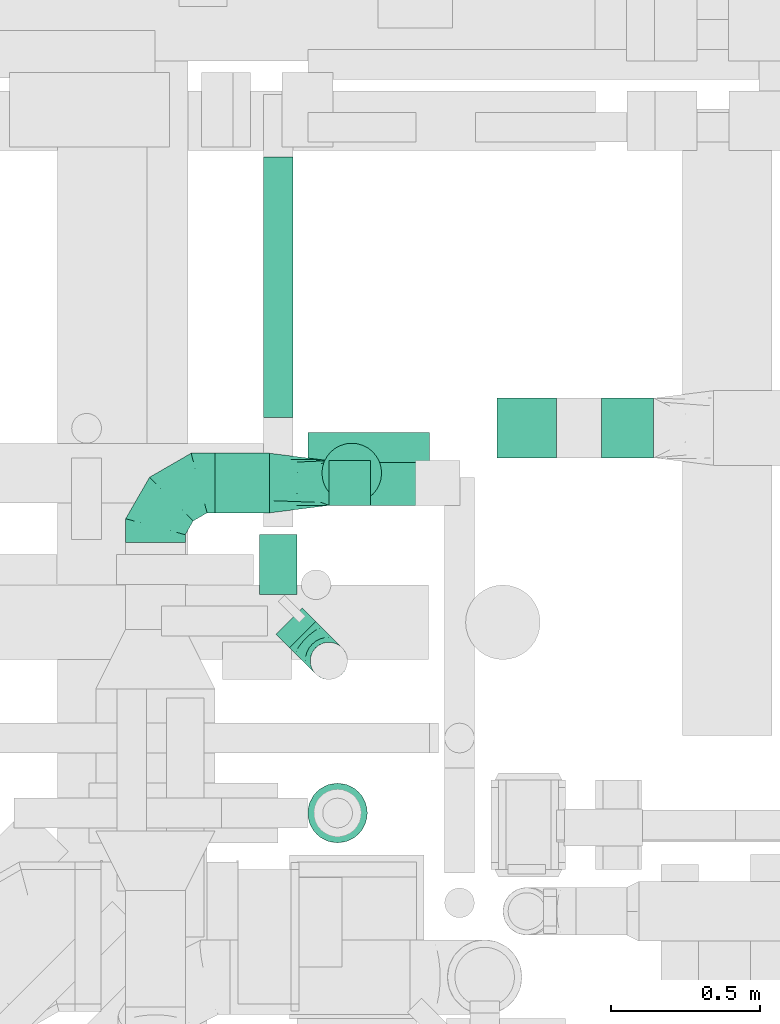
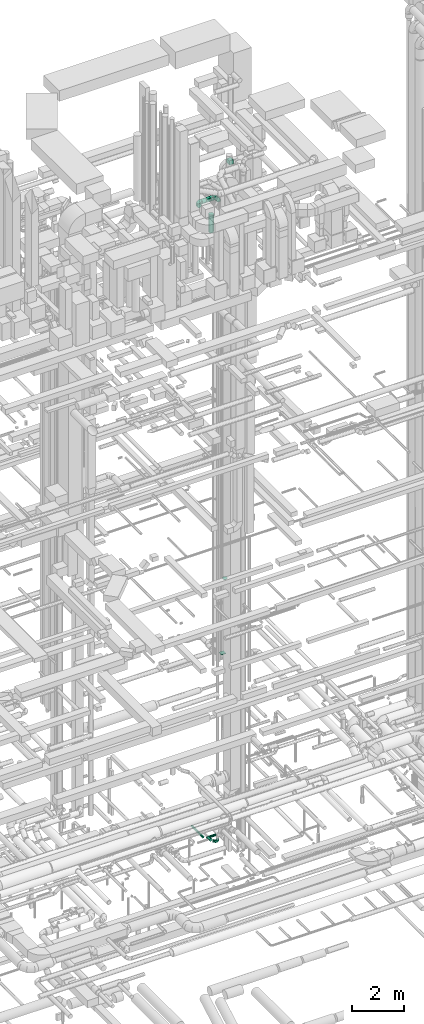
# One storey, part 250 of 337: 8 flow segments, 6 flow fittings.
"""IFC2X3 building model written with IfcOpenShell, lengths in millimetres."""

from ifc_helpers import new_model, entity, si_unit, converted_unit, derived_unit, direction, frame, frame_2d, origin, origin_2d_with_axis, place, context, subcontext, project, spatial, polyline, circle_curve, parameter, trimmed, segment, composite_curve, rectangle, circle, outline, extrude, faceted_brep, source, transform, mapped, material, type_object, type_shapes, element, save


model = new_model("IFC2X3")

# Units and contexts
model_context = context("Model", 3, precision=0.01, world=origin(), true_north=direction((6.12303176911189e-17, 1.0)))
body_context = subcontext(model_context, "Body", "Model", "MODEL_VIEW")
ifc_project = project(units=[si_unit("LENGTHUNIT", "METRE", prefix="MILLI"), si_unit("AREAUNIT", "SQUARE_METRE"), si_unit("VOLUMEUNIT", "CUBIC_METRE"), converted_unit("PLANEANGLEUNIT", "DEGREE", entity("IfcRatioMeasure", 0.0174532925199433), si_unit("PLANEANGLEUNIT", "RADIAN"), dimensions=[0, 0, 0, 0, 0, 0, 0]), si_unit("MASSUNIT", "GRAM", prefix="KILO"), derived_unit("MASSDENSITYUNIT", [(si_unit("MASSUNIT", "GRAM", prefix="KILO"), 1), (si_unit("LENGTHUNIT", "METRE"), -3)]), derived_unit("MOMENTOFINERTIAUNIT", [(si_unit("LENGTHUNIT", "METRE"), 4)]), si_unit("TIMEUNIT", "SECOND"), si_unit("FREQUENCYUNIT", "HERTZ"), si_unit("THERMODYNAMICTEMPERATUREUNIT", "DEGREE_CELSIUS"), derived_unit("THERMALTRANSMITTANCEUNIT", [(si_unit("MASSUNIT", "GRAM", prefix="KILO"), 1), (si_unit("THERMODYNAMICTEMPERATUREUNIT", "KELVIN"), -1), (si_unit("TIMEUNIT", "SECOND"), -3)]), derived_unit("VOLUMETRICFLOWRATEUNIT", [(si_unit("LENGTHUNIT", "METRE"), 3), (si_unit("TIMEUNIT", "SECOND"), -1)]), derived_unit("MASSFLOWRATEUNIT", [(si_unit("MASSUNIT", "GRAM", prefix="KILO"), 1), (si_unit("TIMEUNIT", "SECOND"), -1)]), derived_unit("ROTATIONALFREQUENCYUNIT", [(si_unit("TIMEUNIT", "SECOND"), -1)]), si_unit("ELECTRICCURRENTUNIT", "AMPERE"), si_unit("ELECTRICVOLTAGEUNIT", "VOLT"), si_unit("POWERUNIT", "WATT"), si_unit("FORCEUNIT", "NEWTON", prefix="KILO"), si_unit("ILLUMINANCEUNIT", "LUX"), si_unit("LUMINOUSFLUXUNIT", "LUMEN"), si_unit("LUMINOUSINTENSITYUNIT", "CANDELA"), derived_unit("USERDEFINED", [(si_unit("MASSUNIT", "GRAM", prefix="KILO"), -1), (si_unit("LENGTHUNIT", "METRE"), -2), (si_unit("TIMEUNIT", "SECOND"), 3), (si_unit("LUMINOUSFLUXUNIT", "LUMEN"), 1)]), derived_unit("LINEARVELOCITYUNIT", [(si_unit("LENGTHUNIT", "METRE"), 1), (si_unit("TIMEUNIT", "SECOND"), -1)]), si_unit("PRESSUREUNIT", "PASCAL"), derived_unit("USERDEFINED", [(si_unit("LENGTHUNIT", "METRE"), -2), (si_unit("MASSUNIT", "GRAM", prefix="KILO"), 1), (si_unit("TIMEUNIT", "SECOND"), -2)]), derived_unit("LINEARFORCEUNIT", [(si_unit("MASSUNIT", "GRAM", prefix="KILO"), 1), (si_unit("LENGTHUNIT", "METRE"), 1), (si_unit("TIMEUNIT", "SECOND"), -2), (si_unit("LENGTHUNIT", "METRE"), -1)]), derived_unit("PLANARFORCEUNIT", [(si_unit("MASSUNIT", "GRAM", prefix="KILO"), 1), (si_unit("LENGTHUNIT", "METRE"), 1), (si_unit("TIMEUNIT", "SECOND"), -2), (si_unit("LENGTHUNIT", "METRE"), -2)])], contexts=[model_context])

# Site, building, storey
site_placement = place(None, origin())
site = spatial("IfcSite", under=ifc_project, at=site_placement, CompositionType="ELEMENT")
building_placement = place(site_placement, origin())
building = spatial("IfcBuilding", under=site, at=building_placement, CompositionType="ELEMENT")
storey_placement = place(building_placement, origin())
storey = spatial("IfcBuildingStorey", under=building, at=storey_placement, CompositionType="ELEMENT", Elevation=0.0)

# Flow segments
duct_segment_type_1 = type_object("IfcDuctSegmentType", PredefinedType="NOTDEFINED")
flow_segment_1_placement = place(storey_placement, frame((59799.99, 13045.23, 30500.0)))
element("IfcFlowSegment", 1, at=flow_segment_1_placement, inside=storey, type_object=duct_segment_type_1, context=body_context, shape_type="SweptSolid", body=[
    extrude(rectangle(XDim=175.509511924965, YDim=200.0, at=origin_2d_with_axis()), frame((87.75, 100.0, 0.0), z_axis=(0.0, 0.0, 1.0), x_axis=(-1.0, 0.0, 0.0)), (0.0, 0.0, 1.0), 199.999999999998),
])
flow_segment_2_placement = place(storey_placement, frame((58887.33, 12885.58, 29225.0)))
element("IfcFlowSegment", 2, at=flow_segment_2_placement, inside=storey, type_object=duct_segment_type_1, context=body_context, shape_type="SweptSolid", body=[
    extrude(rectangle(XDim=139.202145893086, YDim=150.000000000001, at=origin_2d_with_axis()), frame((69.6, 75.0, 0.0), z_axis=(0.0, 0.0, 1.0), x_axis=(-1.0, 0.0, 0.0)), (0.0, 0.0, 1.0), 150.000000000001),
])
duct_segment_type_2 = type_object("IfcDuctSegmentType", PredefinedType="NOTDEFINED")
flow_segment_3_placement = place(storey_placement, frame((58816.63, 13028.14, -801.6)))
element("IfcFlowSegment", 3, at=flow_segment_3_placement, inside=storey, type_object=duct_segment_type_2, context=body_context, shape_type="SweptSolid", body=[
    extrude(circle(Radius=50.0, at=origin_2d_with_axis()), frame((0.0, 51.6, 51.6), z_axis=(1.0, 0.0, 0.0), x_axis=(0.0, 1.0, 0.0)), (0.0, 0.0, 1.0), 407.902769999961),
])
flow_segment_4_placement = place(storey_placement, frame((58665.04, 13179.74, -801.6)))
element("IfcFlowSegment", 4, at=flow_segment_4_placement, inside=storey, type_object=duct_segment_type_2, context=body_context, shape_type="SweptSolid", body=[
    extrude(circle(Radius=50.0, at=origin_2d_with_axis()), frame((51.6, 0.0, 51.6), z_axis=(0.0, 1.0, 0.0), x_axis=(1.0, 0.0, 0.0)), (0.0, 0.0, 1.0), 873.533979999998),
])
flow_segment_5_placement = place(storey_placement, frame((58861.71, 12892.42, 27712.86)))
element("IfcFlowSegment", 5, at=flow_segment_5_placement, inside=storey, type_object=duct_segment_type_2, context=body_context, shape_type="SweptSolid", body=[
    extrude(circle(Radius=100.0, at=origin_2d_with_axis()), frame((101.6, 101.6, 0.0), z_axis=(0.0, 0.0, 1.0), x_axis=(0.0, -1.0, 0.0)), (0.0, 0.0, 1.0), 837.140491475748),
])
flow_segment_6_placement = place(storey_placement, frame((58505.03, 12858.99, 29198.4)))
element("IfcFlowSegment", 6, at=flow_segment_6_placement, inside=storey, type_object=duct_segment_type_2, context=body_context, shape_type="SweptSolid", body=[
    extrude(circle(Radius=100.0, at=origin_2d_with_axis()), frame((0.0, 101.6, 101.6), z_axis=(1.0, 0.0, 0.0), x_axis=(0.0, 1.0, 0.0)), (0.0, 0.0, 1.0), 182.292826049876),
])
flow_segment_7_placement = place(storey_placement, frame((58707.45, 12406.92, -584.1)))
element("IfcFlowSegment", 7, at=flow_segment_7_placement, inside=storey, type_object=duct_segment_type_2, context=body_context, shape_type="SweptSolid", body=[
    extrude(circle(Radius=62.5, at=origin_2d_with_axis()), frame((45.79, 90.79, 64.1), z_axis=(0.707106781186548, -0.707106781186548, 0.0), x_axis=(0.707106781186548, 0.707106781186548, 0.0)), (0.0, 0.0, 1.0), 63.6396385910117),
])
flow_segment_8_placement = place(storey_placement, frame((58652.54, 12586.1, -584.1)))
element("IfcFlowSegment", 8, at=flow_segment_8_placement, inside=storey, type_object=duct_segment_type_2, context=body_context, shape_type="SweptSolid", body=[
    extrude(circle(Radius=62.5, at=origin_2d_with_axis()), frame((64.1, 0.0, 64.1), z_axis=(0.0, 1.0, 0.0), x_axis=(-1.0, 0.0, 0.0)), (0.0, 0.0, 1.0), 201.688180861954),
])

# Flow fittings
ifc_material = material()
duct_fitting_type_1 = type_object("IfcDuctFittingType", PredefinedType="NOTDEFINED", material=ifc_material)
shared_shape_1 = source(origin(), body_context, "Body", "SweptSolid", [
    extrude(rectangle(XDim=200.0, YDim=26.0960000001364, at=origin_2d_with_axis()), frame((6.95, 0.0, -100.0), z_axis=(0.0, 0.0, 1.0), x_axis=(0.0, -1.0, 0.0)), (0.0, 0.0, 1.0), 200.0),
])
type_shapes(duct_fitting_type_1, [shared_shape_1])
flow_fitting_1_placement = place(storey_placement, frame((59549.99, 13145.23, 7624.59), z_axis=(0.0, -1.0, 0.0), x_axis=(0.0, 0.0, 1.0)))
element("IfcFlowFitting", 9, at=flow_fitting_1_placement, inside=storey, type_object=duct_fitting_type_1, material=ifc_material, context=body_context, shape_type="MappedRepresentation", body=[
    mapped(shared_shape_1, transform((0.0, 0.0, 0.0), scale=1.0)),
])
duct_fitting_type_2 = type_object("IfcDuctFittingType", PredefinedType="NOTDEFINED", material=ifc_material)
shared_shape_2 = source(origin(), body_context, "Body", "Brep", [
    faceted_brep([(40.0, -58.78, -80.9), (40.0, -30.9, -95.11), (40.0, 0.0, -100.0), (40.0, 30.9, -95.11), (40.0, 58.78, -80.9), (40.0, 80.9, -58.78), (40.0, 95.11, -30.9), (40.0, 100.0, 0.0), (40.0, 95.11, 30.9), (40.0, 80.9, 58.78), (40.0, 58.78, 80.9), (40.0, 30.9, 95.11), (40.0, 0.0, 100.0), (40.0, -30.9, 95.11), (40.0, -58.78, 80.9), (40.0, -80.9, 58.78), (40.0, -95.11, 30.9), (40.0, -100.0, 0.0), (40.0, -95.11, -30.9), (40.0, -80.9, -58.78), (0.0, -30.61, -73.91), (0.0, -43.59, -65.24), (0.0, -56.57, -56.57), (0.0, -65.24, -43.59), (0.0, -73.91, -30.61), (0.0, -76.96, -15.31), (0.0, -80.0, 0.0), (0.0, -76.96, 15.31), (0.0, -73.91, 30.61), (0.0, -65.24, 43.59), (0.0, -56.57, 56.57), (0.0, -43.59, 65.24), (0.0, -30.61, 73.91), (0.0, -15.31, 76.96), (0.0, 0.0, 80.0), (0.0, 15.31, 76.96), (0.0, 30.61, 73.91), (0.0, 43.59, 65.24), (0.0, 56.57, 56.57), (0.0, 65.24, 43.59), (0.0, 73.91, 30.61), (0.0, 76.96, 15.31), (0.0, 80.0, 0.0), (0.0, 76.96, -15.31), (0.0, 73.91, -30.61), (0.0, 65.24, -43.59), (0.0, 56.57, -56.57), (0.0, 43.59, -65.24), (0.0, 30.61, -73.91), (0.0, 15.31, -76.96), (0.0, 0.0, -80.0), (0.0, -15.31, -76.96)], [[[0, 1, 2, 3, 4, 5, 6, 7, 8, 9, 10, 11, 12, 13, 14, 15, 16, 17, 18, 19]], [[20, 21, 22, 23, 24, 25, 26, 27, 28, 29, 30, 31, 32, 33, 34, 35, 36, 37, 38, 39, 40, 41, 42, 43, 44, 45, 46, 47, 48, 49, 50, 51]], [[7, 41, 8]], [[40, 9, 8]], [[10, 38, 37, 36]], [[39, 38, 9, 40]], [[11, 36, 35]], [[34, 12, 35]], [[41, 40, 8]], [[10, 36, 11]], [[35, 12, 11]], [[41, 7, 42]], [[38, 10, 9]], [[12, 33, 13]], [[32, 14, 13]], [[15, 30, 29, 28]], [[31, 30, 14, 32]], [[16, 28, 27]], [[26, 17, 27]], [[33, 32, 13]], [[15, 28, 16]], [[27, 17, 16]], [[33, 12, 34]], [[30, 15, 14]], [[17, 25, 18]], [[24, 19, 18]], [[0, 22, 21, 20]], [[23, 22, 19, 24]], [[1, 20, 51]], [[50, 2, 51]], [[25, 24, 18]], [[0, 20, 1]], [[51, 2, 1]], [[25, 17, 26]], [[22, 0, 19]], [[2, 49, 3]], [[48, 4, 3]], [[5, 46, 45, 44]], [[47, 46, 4, 48]], [[6, 44, 43]], [[42, 7, 43]], [[49, 48, 3]], [[5, 44, 6]], [[43, 7, 6]], [[49, 2, 50]], [[46, 5, 4]]]),
])
type_shapes(duct_fitting_type_2, [shared_shape_2])
flow_fitting_2_placement = place(storey_placement, frame((58915.63, 11854.23, 12120.0), z_axis=(1.0, 0.0, 0.0), x_axis=(0.0, 0.0, 1.0)))
element("IfcFlowFitting", 10, at=flow_fitting_2_placement, inside=storey, type_object=duct_fitting_type_2, material=ifc_material, context=body_context, shape_type="MappedRepresentation", body=[
    mapped(shared_shape_2, transform((0.0, 0.0, 0.0), scale=1.0)),
])
duct_fitting_type_3 = type_object("IfcDuctFittingType", PredefinedType="NOTDEFINED", material=ifc_material)
shared_shape_3 = source(origin(), body_context, "Body", "Brep", [
    faceted_brep([(-200.0, 0.0, -100.0), (-200.0, -25.88, -96.59), (-200.0, -50.0, -86.6), (-200.0, -70.71, -70.71), (-200.0, -86.6, -50.0), (-200.0, -96.59, -25.88), (-200.0, -100.0, 0.0), (-200.0, -96.59, 25.88), (-200.0, -86.6, 50.0), (-200.0, -70.71, 70.71), (-200.0, -50.0, 86.6), (-200.0, -25.88, 96.59), (-200.0, 0.0, 100.0), (-200.0, 25.88, 96.59), (-200.0, 50.0, 86.6), (-200.0, 70.71, 70.71), (-200.0, 86.6, 50.0), (-200.0, 96.59, 25.88), (-200.0, 100.0, 0.0), (-200.0, 96.59, -25.88), (-200.0, 86.6, -50.0), (-200.0, 70.71, -70.71), (-200.0, 50.0, -86.6), (-200.0, 25.88, -96.59), (-153.35, 25.88, 96.59), (-159.81, 50.0, 86.6), (-146.41, 0.0, 100.0), (-165.36, 70.71, 70.71), (-172.29, 96.59, 25.88), (-173.21, 100.0, 0.0), (-169.62, 86.6, 50.0), (-169.62, 86.6, -50.0), (-165.36, 70.71, -70.71), (-172.29, 96.59, -25.88), (-153.35, 25.88, -96.59), (-146.41, 0.0, -100.0), (-159.81, 50.0, -86.6), (-139.48, -25.88, -96.59), (-133.01, -50.0, -86.6), (-127.46, -70.71, -70.71), (-123.21, -86.6, -50.0), (-120.53, -96.59, -25.88), (-119.62, -100.0, 0.0), (-120.53, -96.59, 25.88), (-123.21, -86.6, 50.0), (-127.46, -70.71, 70.71), (-133.01, -50.0, 86.6), (-139.48, -25.88, 96.59), (-72.54, 72.54, 96.59), (-90.19, 90.19, 86.6), (-53.59, 53.59, 100.0), (-105.35, 105.35, 70.71), (-116.99, 116.99, 50.0), (-124.3, 124.3, 25.88), (-126.79, 126.79, 0.0), (-124.3, 124.3, -25.88), (-116.99, 116.99, -50.0), (-105.35, 105.35, -70.71), (-72.54, 72.54, -96.59), (-53.59, 53.59, -100.0), (-90.19, 90.19, -86.6), (-34.64, 34.64, -96.59), (-16.99, 16.99, -86.6), (-1.83, 1.83, -70.71), (9.81, -9.81, -50.0), (17.12, -17.12, -25.88), (19.62, -19.62, 0.0), (17.12, -17.12, 25.88), (9.81, -9.81, 50.0), (-1.83, 1.83, 70.71), (-16.99, 16.99, 86.6), (-34.64, 34.64, 96.59), (-25.88, 153.35, 96.59), (-50.0, 159.81, 86.6), (0.0, 146.41, 100.0), (-70.71, 165.36, 70.71), (-86.6, 169.62, 50.0), (-96.59, 172.29, 25.88), (-100.0, 173.21, 0.0), (-96.59, 172.29, -25.88), (-86.6, 169.62, -50.0), (-70.71, 165.36, -70.71), (-25.88, 153.35, -96.59), (0.0, 146.41, -100.0), (-50.0, 159.81, -86.6), (25.88, 139.48, -96.59), (50.0, 133.01, -86.6), (70.71, 127.46, -70.71), (86.6, 123.21, -50.0), (96.59, 120.53, -25.88), (100.0, 119.62, 0.0), (96.59, 120.53, 25.88), (86.6, 123.21, 50.0), (70.71, 127.46, 70.71), (50.0, 133.01, 86.6), (25.88, 139.48, 96.59), (-25.88, 200.0, -96.59), (-50.0, 200.0, -86.6), (-70.71, 200.0, -70.71), (-86.6, 200.0, -50.0), (-96.59, 200.0, -25.88), (-100.0, 200.0, 0.0), (-96.59, 200.0, 25.88), (-86.6, 200.0, 50.0), (-70.71, 200.0, 70.71), (-50.0, 200.0, 86.6), (-25.88, 200.0, 96.59), (0.0, 200.0, 100.0), (25.88, 200.0, 96.59), (50.0, 200.0, 86.6), (70.71, 200.0, 70.71), (86.6, 200.0, 50.0), (96.59, 200.0, 25.88), (100.0, 200.0, 0.0), (96.59, 200.0, -25.88), (86.6, 200.0, -50.0), (70.71, 200.0, -70.71), (50.0, 200.0, -86.6), (25.88, 200.0, -96.59), (0.0, 200.0, -100.0)], [[[0, 1, 2, 3, 4, 5, 6, 7, 8, 9, 10, 11, 12, 13, 14, 15, 16, 17, 18, 19, 20, 21, 22, 23]], [[24, 25, 14, 13]], [[26, 24, 13, 12]], [[14, 25, 27, 15]], [[28, 29, 18, 17]], [[30, 28, 17, 16]], [[15, 27, 30, 16]], [[20, 31, 32, 21]], [[33, 31, 20, 19]], [[18, 29, 33, 19]], [[34, 35, 0, 23]], [[36, 34, 23, 22]], [[32, 36, 22, 21]], [[1, 0, 35, 37]], [[2, 1, 37, 38]], [[38, 39, 3, 2]], [[5, 4, 40, 41]], [[6, 5, 41, 42]], [[39, 40, 4, 3]], [[6, 42, 43, 7]], [[7, 43, 44, 8]], [[8, 44, 45, 9]], [[9, 45, 46, 10]], [[10, 46, 47, 11]], [[26, 12, 11, 47]], [[48, 49, 25, 24]], [[50, 48, 24, 26]], [[27, 25, 49, 51]], [[52, 53, 28, 30]], [[51, 52, 30, 27]], [[29, 28, 53, 54]], [[55, 56, 31, 33]], [[54, 55, 33, 29]], [[32, 31, 56, 57]], [[58, 59, 35, 34]], [[60, 58, 34, 36]], [[57, 60, 36, 32]], [[37, 35, 59, 61]], [[38, 37, 61, 62]], [[39, 38, 62, 63]], [[41, 40, 64, 65]], [[42, 41, 65, 66]], [[63, 64, 40, 39]], [[43, 42, 66, 67]], [[44, 43, 67, 68]], [[68, 69, 45, 44]], [[46, 45, 69, 70]], [[47, 46, 70, 71]], [[26, 47, 71, 50]], [[72, 73, 49, 48]], [[74, 72, 48, 50]], [[51, 49, 73, 75]], [[76, 77, 53, 52]], [[75, 76, 52, 51]], [[54, 53, 77, 78]], [[79, 80, 56, 55]], [[78, 79, 55, 54]], [[57, 56, 80, 81]], [[82, 83, 59, 58]], [[84, 82, 58, 60]], [[81, 84, 60, 57]], [[61, 59, 83, 85]], [[62, 61, 85, 86]], [[63, 62, 86, 87]], [[65, 64, 88, 89]], [[66, 65, 89, 90]], [[87, 88, 64, 63]], [[67, 66, 90, 91]], [[68, 67, 91, 92]], [[92, 93, 69, 68]], [[70, 69, 93, 94]], [[71, 70, 94, 95]], [[50, 71, 95, 74]], [[96, 97, 98, 99, 100, 101, 102, 103, 104, 105, 106, 107, 108, 109, 110, 111, 112, 113, 114, 115, 116, 117, 118, 119]], [[72, 74, 107, 106]], [[73, 72, 106, 105]], [[75, 73, 105, 104]], [[102, 101, 78, 77]], [[103, 102, 77, 76]], [[75, 104, 103, 76]], [[78, 101, 100, 79]], [[79, 100, 99, 80]], [[80, 99, 98, 81]], [[84, 97, 96, 82]], [[82, 96, 119, 83]], [[84, 81, 98, 97]], [[118, 117, 86, 85]], [[119, 118, 85, 83]], [[116, 87, 86, 117]], [[88, 115, 114, 89]], [[89, 114, 113, 90]], [[115, 88, 87, 116]], [[91, 90, 113, 112]], [[92, 91, 112, 111]], [[111, 110, 93, 92]], [[95, 94, 109, 108]], [[74, 95, 108, 107]], [[110, 109, 94, 93]]]),
])
type_shapes(duct_fitting_type_3, [shared_shape_3])
flow_fitting_3_placement = place(storey_placement, frame((58305.03, 12960.58, 29300.0), z_axis=(-1.86436468177398e-08, 0.0, 1.0), x_axis=(-1.0, 0.0, -1.86436468177398e-08)))
element("IfcFlowFitting", 11, at=flow_fitting_3_placement, inside=storey, type_object=duct_fitting_type_3, material=ifc_material, context=body_context, shape_type="MappedRepresentation", body=[
    mapped(shared_shape_3, transform((0.0, 0.0, 0.0), scale=1.0)),
])
duct_fitting_type_4 = type_object("IfcDuctFittingType", PredefinedType="NOTDEFINED", material=ifc_material)
shared_shape_4 = source(origin(), body_context, "Body", "Brep", [
    faceted_brep([(-125.0, 0.0, -62.5), (-125.0, -16.18, -60.37), (-125.0, -31.25, -54.13), (-125.0, -44.19, -44.19), (-125.0, -54.13, -31.25), (-125.0, -60.37, -16.18), (-125.0, -62.5, 0.0), (-125.0, -60.37, 16.18), (-125.0, -54.13, 31.25), (-125.0, -44.19, 44.19), (-125.0, -31.25, 54.13), (-125.0, -16.18, 60.37), (-125.0, 0.0, 62.5), (-125.0, 16.18, 60.37), (-125.0, 31.25, 54.13), (-125.0, 44.19, 44.19), (-125.0, 54.13, 31.25), (-125.0, 60.37, 16.18), (-125.0, 62.5, 0.0), (-125.0, 60.37, -16.18), (-125.0, 54.13, -31.25), (-125.0, 44.19, -44.19), (-125.0, 31.25, -54.13), (-125.0, 16.18, -60.37), (-95.84, 16.18, 60.37), (-99.88, 31.25, 54.13), (-91.51, 0.0, 62.5), (-103.35, 44.19, 44.19), (-107.68, 60.37, 16.18), (-108.25, 62.5, 0.0), (-106.01, 54.13, 31.25), (-106.01, 54.13, -31.25), (-103.35, 44.19, -44.19), (-107.68, 60.37, -16.18), (-95.84, 16.18, -60.37), (-91.51, 0.0, -62.5), (-99.88, 31.25, -54.13), (-87.17, -16.18, -60.37), (-83.13, -31.25, -54.13), (-79.66, -44.19, -44.19), (-77.0, -54.13, -31.25), (-75.33, -60.37, -16.18), (-74.76, -62.5, 0.0), (-75.33, -60.37, 16.18), (-77.0, -54.13, 31.25), (-79.66, -44.19, 44.19), (-83.13, -31.25, 54.13), (-87.17, -16.18, 60.37), (-45.34, 45.34, 60.37), (-56.37, 56.37, 54.13), (-33.49, 33.49, 62.5), (-65.85, 65.85, 44.19), (-73.12, 73.12, 31.25), (-77.69, 77.69, 16.18), (-79.25, 79.25, 0.0), (-77.69, 77.69, -16.18), (-73.12, 73.12, -31.25), (-65.85, 65.85, -44.19), (-45.34, 45.34, -60.37), (-33.49, 33.49, -62.5), (-56.37, 56.37, -54.13), (-21.65, 21.65, -60.37), (-10.62, 10.62, -54.13), (-1.14, 1.14, -44.19), (6.13, -6.13, -31.25), (10.7, -10.7, -16.18), (12.26, -12.26, 0.0), (10.7, -10.7, 16.18), (6.13, -6.13, 31.25), (-1.14, 1.14, 44.19), (-10.62, 10.62, 54.13), (-21.65, 21.65, 60.37), (-16.18, 95.84, 60.37), (-31.25, 99.88, 54.13), (0.0, 91.51, 62.5), (-44.19, 103.35, 44.19), (-54.13, 106.01, 31.25), (-60.37, 107.68, 16.18), (-62.5, 108.25, 0.0), (-60.37, 107.68, -16.18), (-54.13, 106.01, -31.25), (-44.19, 103.35, -44.19), (-16.18, 95.84, -60.37), (0.0, 91.51, -62.5), (-31.25, 99.88, -54.13), (16.18, 87.17, -60.37), (31.25, 83.13, -54.13), (44.19, 79.66, -44.19), (54.13, 77.0, -31.25), (60.37, 75.33, -16.18), (62.5, 74.76, 0.0), (60.37, 75.33, 16.18), (54.13, 77.0, 31.25), (44.19, 79.66, 44.19), (31.25, 83.13, 54.13), (16.18, 87.17, 60.37), (-16.18, 125.0, -60.37), (-31.25, 125.0, -54.13), (-44.19, 125.0, -44.19), (-54.13, 125.0, -31.25), (-60.37, 125.0, -16.18), (-62.5, 125.0, 0.0), (-60.37, 125.0, 16.18), (-54.13, 125.0, 31.25), (-44.19, 125.0, 44.19), (-31.25, 125.0, 54.13), (-16.18, 125.0, 60.37), (0.0, 125.0, 62.5), (16.18, 125.0, 60.37), (31.25, 125.0, 54.13), (44.19, 125.0, 44.19), (54.13, 125.0, 31.25), (60.37, 125.0, 16.18), (62.5, 125.0, 0.0), (60.37, 125.0, -16.18), (54.13, 125.0, -31.25), (44.19, 125.0, -44.19), (31.25, 125.0, -54.13), (16.18, 125.0, -60.37), (0.0, 125.0, -62.5)], [[[0, 1, 2, 3, 4, 5, 6, 7, 8, 9, 10, 11, 12, 13, 14, 15, 16, 17, 18, 19, 20, 21, 22, 23]], [[24, 25, 14, 13]], [[26, 24, 13, 12]], [[14, 25, 27, 15]], [[28, 29, 18, 17]], [[30, 28, 17, 16]], [[15, 27, 30, 16]], [[20, 31, 32, 21]], [[33, 31, 20, 19]], [[18, 29, 33, 19]], [[34, 35, 0, 23]], [[36, 34, 23, 22]], [[21, 32, 36, 22]], [[1, 0, 35, 37]], [[2, 1, 37, 38]], [[38, 39, 3, 2]], [[5, 4, 40, 41]], [[6, 5, 41, 42]], [[39, 40, 4, 3]], [[6, 42, 43, 7]], [[7, 43, 44, 8]], [[45, 9, 8, 44]], [[9, 45, 46, 10]], [[10, 46, 47, 11]], [[26, 12, 11, 47]], [[48, 49, 25, 24]], [[50, 48, 24, 26]], [[27, 25, 49, 51]], [[52, 53, 28, 30]], [[51, 52, 30, 27]], [[29, 28, 53, 54]], [[55, 56, 31, 33]], [[54, 55, 33, 29]], [[57, 32, 31, 56]], [[58, 59, 35, 34]], [[60, 58, 34, 36]], [[57, 60, 36, 32]], [[37, 35, 59, 61]], [[38, 37, 61, 62]], [[39, 38, 62, 63]], [[41, 40, 64, 65]], [[42, 41, 65, 66]], [[63, 64, 40, 39]], [[43, 42, 66, 67]], [[44, 43, 67, 68]], [[68, 69, 45, 44]], [[46, 45, 69, 70]], [[47, 46, 70, 71]], [[26, 47, 71, 50]], [[72, 73, 49, 48]], [[74, 72, 48, 50]], [[51, 49, 73, 75]], [[76, 77, 53, 52]], [[75, 76, 52, 51]], [[54, 53, 77, 78]], [[79, 80, 56, 55]], [[78, 79, 55, 54]], [[81, 57, 56, 80]], [[82, 83, 59, 58]], [[84, 82, 58, 60]], [[81, 84, 60, 57]], [[61, 59, 83, 85]], [[62, 61, 85, 86]], [[63, 62, 86, 87]], [[65, 64, 88, 89]], [[66, 65, 89, 90]], [[87, 88, 64, 63]], [[67, 66, 90, 91]], [[68, 67, 91, 92]], [[92, 93, 69, 68]], [[70, 69, 93, 94]], [[71, 70, 94, 95]], [[50, 71, 95, 74]], [[96, 97, 98, 99, 100, 101, 102, 103, 104, 105, 106, 107, 108, 109, 110, 111, 112, 113, 114, 115, 116, 117, 118, 119]], [[72, 74, 107, 106]], [[73, 72, 106, 105]], [[75, 73, 105, 104]], [[77, 76, 103, 102]], [[78, 77, 102, 101]], [[75, 104, 103, 76]], [[78, 101, 100, 79]], [[79, 100, 99, 80]], [[80, 99, 98, 81]], [[96, 119, 83, 82]], [[97, 96, 82, 84]], [[84, 81, 98, 97]], [[83, 119, 118, 85]], [[85, 118, 117, 86]], [[116, 87, 86, 117]], [[88, 115, 114, 89]], [[89, 114, 113, 90]], [[115, 88, 87, 116]], [[91, 90, 113, 112]], [[92, 91, 112, 111]], [[111, 110, 93, 92]], [[95, 94, 109, 108]], [[74, 95, 108, 107]], [[110, 109, 94, 93]]]),
])
type_shapes(duct_fitting_type_4, [shared_shape_4])
flow_fitting_4_placement = place(storey_placement, frame((58886.63, 12364.32, -520.0), z_axis=(0.707106781186543, 0.707106781186552, 0.0), x_axis=(0.0, 0.0, -1.0)))
element("IfcFlowFitting", 12, at=flow_fitting_4_placement, inside=storey, type_object=duct_fitting_type_4, material=ifc_material, context=body_context, shape_type="MappedRepresentation", body=[
    mapped(shared_shape_4, transform((0.0, 0.0, 0.0), scale=1.0)),
])
duct_fitting_type_5 = type_object("IfcDuctFittingType", PredefinedType="NOTDEFINED", material=ifc_material)
shared_shape_5 = source(origin(), body_context, "Body", "Brep", [
    faceted_brep([(200.0, 30.9, 95.11), (200.0, 19.08, 96.98), (200.0, 9.54, 98.49), (200.0, 4.77, 99.24), (200.0, 0.0, 100.0), (200.0, -4.77, 99.24), (200.0, -9.54, 98.49), (200.0, -19.08, 96.98), (200.0, -30.9, 95.11), (200.0, -44.84, 88.0), (200.0, -58.78, 80.9), (200.0, -69.84, 69.84), (200.0, -80.9, 58.78), (200.0, -88.0, 44.84), (200.0, -95.11, 30.9), (200.0, -96.98, 19.08), (200.0, -98.49, 9.54), (200.0, -99.24, 4.77), (200.0, -100.0, 0.0), (200.0, -99.24, -4.77), (200.0, -98.49, -9.54), (200.0, -96.98, -19.08), (200.0, -95.11, -30.9), (200.0, -88.0, -44.84), (200.0, -80.9, -58.78), (200.0, -69.84, -69.84), (200.0, -58.78, -80.9), (200.0, -44.84, -88.0), (200.0, -30.9, -95.11), (200.0, -19.08, -96.98), (200.0, -9.54, -98.49), (200.0, -4.77, -99.24), (200.0, 0.0, -100.0), (200.0, 4.77, -99.24), (200.0, 9.54, -98.49), (200.0, 19.08, -96.98), (200.0, 30.9, -95.11), (200.0, 44.84, -88.0), (200.0, 58.78, -80.9), (200.0, 69.84, -69.84), (200.0, 80.9, -58.78), (200.0, 88.0, -44.84), (200.0, 95.11, -30.9), (200.0, 96.98, -19.08), (200.0, 98.49, -9.54), (200.0, 99.24, -4.77), (200.0, 100.0, 0.0), (200.0, 99.24, 4.77), (200.0, 98.49, 9.54), (200.0, 96.98, 19.08), (200.0, 95.11, 30.9), (200.0, 88.0, 44.84), (200.0, 80.9, 58.78), (200.0, 69.84, 69.84), (200.0, 58.78, 80.9), (200.0, 44.84, 88.0), (0.0, -75.0, 75.0), (0.0, 75.0, 75.0), (0.0, 75.0, -75.0), (0.0, -75.0, -75.0), (104.11, -35.96, 88.01), (100.0, -70.65, 74.93), (26.03, -65.24, 78.25), (78.09, -45.72, 84.76), (52.06, -55.48, 81.51), (188.01, -4.49, 98.5), (176.03, -8.99, 97.0), (152.06, -17.98, 94.01), (128.09, -26.97, 91.01), (52.06, -81.51, 55.48), (78.09, -84.76, 45.72), (104.11, -88.01, 35.96), (128.09, -91.01, 26.97), (152.06, -94.01, 17.98), (176.03, -97.0, 8.99), (188.01, -98.5, 4.49), (26.03, -78.25, 65.24), (26.03, -78.25, -65.24), (52.06, -81.51, -55.48), (78.09, -84.76, -45.72), (104.11, -88.01, -35.96), (128.09, -91.01, -26.97), (152.06, -94.01, -17.98), (176.03, -97.0, -8.99), (188.01, -98.5, -4.49), (100.0, -74.93, -70.65), (52.06, -55.48, -81.51), (78.09, -45.72, -84.76), (104.11, -35.96, -88.01), (128.09, -26.97, -91.01), (152.06, -17.98, -94.01), (176.03, -8.99, -97.0), (188.01, -4.49, -98.5), (26.03, -65.24, -78.25), (26.03, 65.24, -78.25), (52.06, 55.48, -81.51), (78.09, 45.72, -84.76), (104.11, 35.96, -88.01), (128.09, 26.97, -91.01), (152.06, 17.98, -94.01), (176.03, 8.99, -97.0), (188.01, 4.49, -98.5), (100.0, 70.65, -74.93), (52.06, 81.51, -55.48), (78.09, 84.76, -45.72), (104.11, 88.01, -35.96), (128.09, 91.01, -26.97), (152.06, 94.01, -17.98), (176.03, 97.0, -8.99), (188.01, 98.5, -4.49), (26.03, 78.25, -65.24), (26.03, 78.25, 65.24), (52.06, 81.51, 55.48), (78.09, 84.76, 45.72), (104.11, 88.01, 35.96), (128.09, 91.01, 26.97), (152.06, 94.01, 17.98), (176.03, 97.0, 8.99), (188.01, 98.5, 4.49), (100.0, 74.93, 70.65), (52.06, 55.48, 81.51), (78.09, 45.72, 84.76), (104.11, 35.96, 88.01), (128.09, 26.97, 91.01), (152.06, 17.98, 94.01), (176.03, 8.99, 97.0), (188.01, 4.49, 98.5), (26.03, 65.24, 78.25)], [[[0, 1, 2, 3, 4, 5, 6, 7, 8, 9, 10, 11, 12, 13, 14, 15, 16, 17, 18, 19, 20, 21, 22, 23, 24, 25, 26, 27, 28, 29, 30, 31, 32, 33, 34, 35, 36, 37, 38, 39, 40, 41, 42, 43, 44, 45, 46, 47, 48, 49, 50, 51, 52, 53, 54, 55]], [[56, 57, 58, 59]], [[60, 9, 8]], [[56, 61, 62]], [[9, 60, 63, 64]], [[65, 66, 67, 68, 60, 8, 7, 6, 5, 4]], [[62, 61, 10]], [[13, 69, 70, 71]], [[64, 10, 9]], [[14, 71, 72, 73, 74, 75, 18, 17, 16, 15]], [[12, 76, 69]], [[71, 14, 13]], [[61, 76, 11]], [[10, 64, 62]], [[76, 12, 11]], [[10, 61, 11]], [[61, 56, 76]], [[69, 13, 12]], [[75, 74, 73, 72, 71, 70, 69, 76, 56, 59, 77, 78, 79, 80, 81, 82, 83, 84, 18]], [[80, 23, 22]], [[59, 85, 77]], [[23, 80, 79, 78]], [[84, 83, 82, 81, 80, 22, 21, 20, 19, 18]], [[77, 85, 24]], [[27, 86, 87, 88]], [[78, 24, 23]], [[28, 88, 89, 90, 91, 92, 32, 31, 30, 29]], [[26, 93, 86]], [[88, 28, 27]], [[85, 93, 25]], [[24, 78, 77]], [[93, 26, 25]], [[24, 85, 25]], [[85, 59, 93]], [[86, 27, 26]], [[92, 91, 90, 89, 88, 87, 86, 93, 59, 58, 94, 95, 96, 97, 98, 99, 100, 101, 32]], [[97, 37, 36]], [[58, 102, 94]], [[37, 97, 96, 95]], [[101, 100, 99, 98, 97, 36, 35, 34, 33, 32]], [[94, 102, 38]], [[41, 103, 104, 105]], [[95, 38, 37]], [[42, 105, 106, 107, 108, 109, 46, 45, 44, 43]], [[40, 110, 103]], [[105, 42, 41]], [[102, 110, 39]], [[38, 95, 94]], [[110, 40, 39]], [[38, 102, 39]], [[102, 58, 110]], [[103, 41, 40]], [[58, 57, 111, 112, 113, 114, 115, 116, 117, 118, 46, 109, 108, 107, 106, 105, 104, 103, 110]], [[114, 51, 50]], [[57, 119, 111]], [[51, 114, 113, 112]], [[118, 117, 116, 115, 114, 50, 49, 48, 47, 46]], [[111, 119, 52]], [[55, 120, 121, 122]], [[112, 52, 51]], [[0, 122, 123, 124, 125, 126, 4, 3, 2, 1]], [[54, 127, 120]], [[122, 0, 55]], [[119, 127, 53]], [[52, 112, 111]], [[127, 54, 53]], [[52, 119, 53]], [[119, 57, 127]], [[120, 55, 54]], [[57, 56, 62, 64, 63, 60, 68, 67, 66, 65, 4, 126, 125, 124, 123, 122, 121, 120, 127]]]),
])
type_shapes(duct_fitting_type_5, [shared_shape_5])
flow_fitting_5_placement = place(storey_placement, frame((58887.33, 12960.58, 29300.0), z_axis=(0.0, 0.0, 1.0), x_axis=(-1.0, 0.0, 0.0)))
element("IfcFlowFitting", 13, at=flow_fitting_5_placement, inside=storey, type_object=duct_fitting_type_5, material=ifc_material, context=body_context, shape_type="MappedRepresentation", body=[
    mapped(shared_shape_5, transform((0.0, 0.0, 0.0), scale=1.0)),
])
duct_fitting_type_6 = type_object("IfcDuctFittingType", PredefinedType="NOTDEFINED", material=ifc_material)
shared_shape_6 = source(origin(), body_context, "Body", "SweptSolid", [
    extrude(outline(composite_curve([segment(polyline([(-187.5, -112.5), (-37.5, -112.5)]), True, "CONTINUOUS"), segment(trimmed(circle_curve(frame_2d((112.5, -112.5), x_axis=(1.81194195505441e-05, 1.0)), 150.0), [parameter(0.0)], [parameter(90.0010381662673)], True, "PARAMETER"), False, "CONTINUOUS"), segment(polyline([(112.5, 37.5), (112.5, 187.5)]), True, "CONTINUOUS"), segment(trimmed(circle_curve(frame_2d((112.5, -112.5), x_axis=(1.81194195505441e-05, 1.0)), 300.0), [parameter(0.0)], [parameter(90.0010381662673)], True, "PARAMETER"), True, "CONTINUOUS")], self_intersect=False)), frame((-112.5, 112.5, -75.0), z_axis=(0.0, 0.0, 1.0), x_axis=(-1.0, -1.81194195447532e-05, 0.0)), (0.0, 0.0, 1.0), 150.0),
])
type_shapes(duct_fitting_type_6, [shared_shape_6])
flow_fitting_6_placement = place(storey_placement, frame((59251.53, 12960.58, 29300.0), z_axis=(0.0, -1.0, 0.0), x_axis=(1.81194195446342e-05, 0.0, 1.0)))
element("IfcFlowFitting", 14, at=flow_fitting_6_placement, inside=storey, type_object=duct_fitting_type_6, material=ifc_material, context=body_context, shape_type="MappedRepresentation", body=[
    mapped(shared_shape_6, transform((0.0, 0.0, 0.0), scale=1.0)),
])

save(model, "model.ifc")
